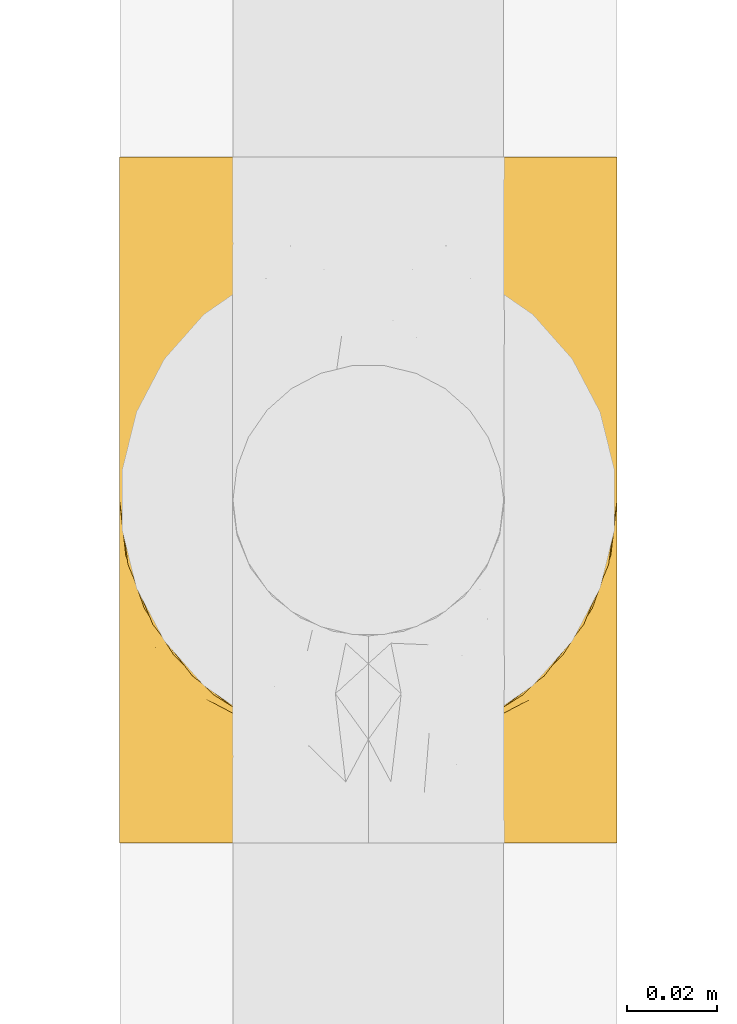
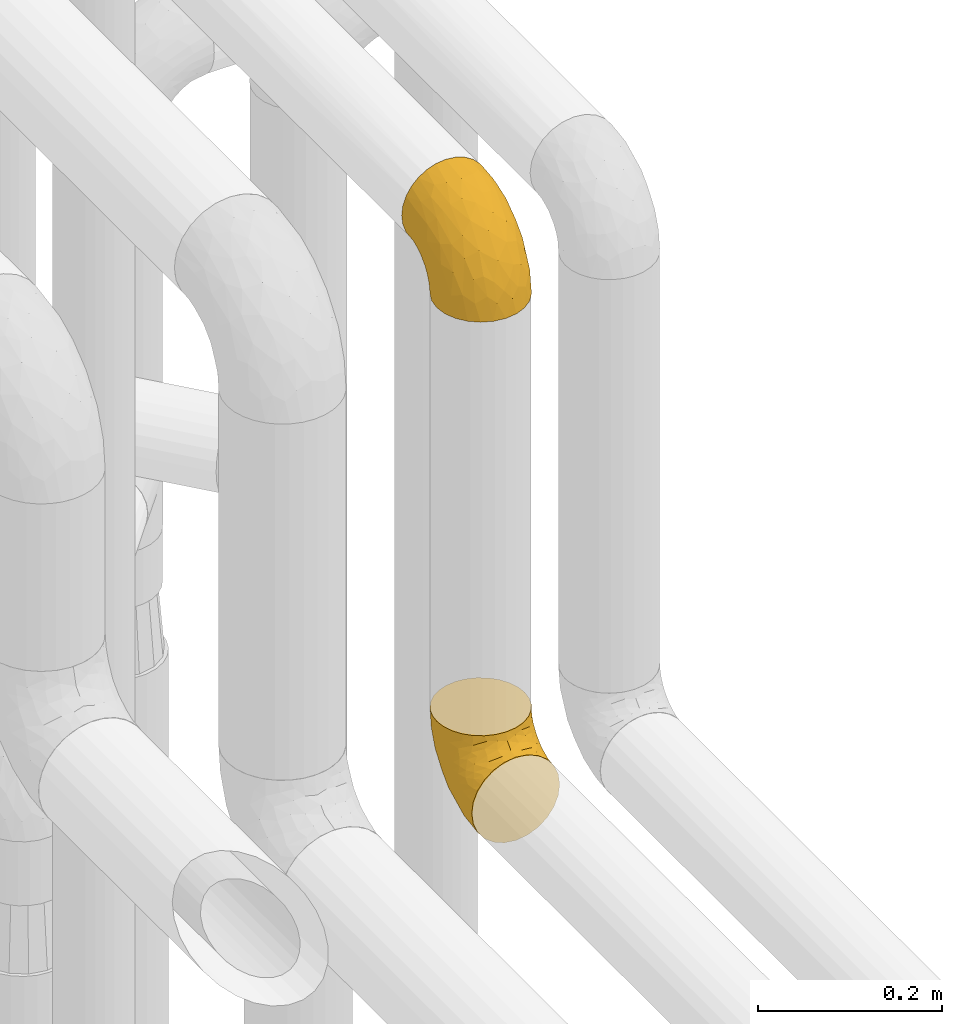
# One storey, part 188 of 827: 2 coverings.
"""IFC2X3 building model written with IfcOpenShell, lengths in millimetres."""

from ifc_helpers import new_model, entity, si_unit, converted_unit, derived_unit, direction, frame, origin, place, context, subcontext, project, spatial, faceted_brep, element, save


model = new_model("IFC2X3")

# Units and contexts
model_context = context("Model", 3, precision=0.01, world=origin(), true_north=direction((6.12303176911189e-17, 1.0)))
body_context = subcontext(model_context, "Body", "Model", "MODEL_VIEW")
ifc_project = project(units=[si_unit("LENGTHUNIT", "METRE", prefix="MILLI"), si_unit("AREAUNIT", "SQUARE_METRE"), si_unit("VOLUMEUNIT", "CUBIC_METRE"), converted_unit("PLANEANGLEUNIT", "DEGREE", entity("IfcRatioMeasure", 0.0174532925199433), si_unit("PLANEANGLEUNIT", "RADIAN"), dimensions=[0, 0, 0, 0, 0, 0, 0]), si_unit("MASSUNIT", "GRAM", prefix="KILO"), derived_unit("MASSDENSITYUNIT", [(si_unit("MASSUNIT", "GRAM", prefix="KILO"), 1), (si_unit("LENGTHUNIT", "METRE"), -3)]), derived_unit("MOMENTOFINERTIAUNIT", [(si_unit("LENGTHUNIT", "METRE"), 4)]), si_unit("TIMEUNIT", "SECOND"), si_unit("FREQUENCYUNIT", "HERTZ"), si_unit("THERMODYNAMICTEMPERATUREUNIT", "DEGREE_CELSIUS"), derived_unit("THERMALTRANSMITTANCEUNIT", [(si_unit("MASSUNIT", "GRAM", prefix="KILO"), 1), (si_unit("THERMODYNAMICTEMPERATUREUNIT", "KELVIN"), -1), (si_unit("TIMEUNIT", "SECOND"), -3)]), derived_unit("VOLUMETRICFLOWRATEUNIT", [(si_unit("LENGTHUNIT", "METRE"), 3), (si_unit("TIMEUNIT", "SECOND"), -1)]), derived_unit("MASSFLOWRATEUNIT", [(si_unit("MASSUNIT", "GRAM", prefix="KILO"), 1), (si_unit("TIMEUNIT", "SECOND"), -1)]), derived_unit("ROTATIONALFREQUENCYUNIT", [(si_unit("TIMEUNIT", "SECOND"), -1)]), si_unit("ELECTRICCURRENTUNIT", "AMPERE"), si_unit("ELECTRICVOLTAGEUNIT", "VOLT"), si_unit("POWERUNIT", "WATT"), si_unit("FORCEUNIT", "NEWTON", prefix="KILO"), si_unit("ILLUMINANCEUNIT", "LUX"), si_unit("LUMINOUSFLUXUNIT", "LUMEN"), si_unit("LUMINOUSINTENSITYUNIT", "CANDELA"), derived_unit("USERDEFINED", [(si_unit("MASSUNIT", "GRAM", prefix="KILO"), -1), (si_unit("LENGTHUNIT", "METRE"), -2), (si_unit("TIMEUNIT", "SECOND"), 3), (si_unit("LUMINOUSFLUXUNIT", "LUMEN"), 1)]), derived_unit("LINEARVELOCITYUNIT", [(si_unit("LENGTHUNIT", "METRE"), 1), (si_unit("TIMEUNIT", "SECOND"), -1)]), si_unit("PRESSUREUNIT", "PASCAL"), derived_unit("USERDEFINED", [(si_unit("LENGTHUNIT", "METRE"), -2), (si_unit("MASSUNIT", "GRAM", prefix="KILO"), 1), (si_unit("TIMEUNIT", "SECOND"), -2)]), derived_unit("LINEARFORCEUNIT", [(si_unit("MASSUNIT", "GRAM", prefix="KILO"), 1), (si_unit("LENGTHUNIT", "METRE"), 1), (si_unit("TIMEUNIT", "SECOND"), -2), (si_unit("LENGTHUNIT", "METRE"), -1)]), derived_unit("PLANARFORCEUNIT", [(si_unit("MASSUNIT", "GRAM", prefix="KILO"), 1), (si_unit("LENGTHUNIT", "METRE"), 1), (si_unit("TIMEUNIT", "SECOND"), -2), (si_unit("LENGTHUNIT", "METRE"), -2)])], contexts=[model_context])

# Site, building, storey
site_placement = place(None, origin())
site = spatial("IfcSite", under=ifc_project, at=site_placement, CompositionType="ELEMENT")
building_placement = place(site_placement, origin())
building = spatial("IfcBuilding", under=site, at=building_placement, CompositionType="ELEMENT")
storey_placement = place(building_placement, frame((0.0, 0.0, 28200.0)))
storey = spatial("IfcBuildingStorey", under=building, at=storey_placement, Name="08", CompositionType="ELEMENT", Elevation=28200.0)

# Coverings
covering_1_placement = place(storey_placement, frame((36411.97, 8729.79, 2793.25)))
element("IfcCovering", 1, at=covering_1_placement, inside=storey, Name=":ADSK_", ObjectType=":ADSK_", PredefinedType="INSULATION", context=body_context, shape_type="Brep", body=[
    faceted_brep([(111.9, 77.6, 132.75), (110.51, 89.87, 132.75), (106.43, 101.53, 132.75), (99.86, 111.99, 132.75), (91.12, 120.72, 132.75), (80.66, 127.29, 132.75), (69.0, 131.37, 132.75), (56.75, 132.75, 132.75), (44.47, 131.36, 132.75), (32.81, 127.28, 132.75), (22.35, 120.71, 132.75), (13.62, 111.97, 132.75), (7.05, 101.51, 132.75), (2.97, 89.85, 132.75), (1.6, 77.6, 132.75), (2.55, 69.16, 132.75), (2.98, 65.32, 132.75), (5.02, 59.49, 132.75), (7.06, 53.66, 132.75), (13.63, 43.2, 132.75), (22.37, 34.47, 132.75), (32.83, 27.9, 132.75), (44.49, 23.82, 132.75), (56.75, 22.45, 132.75), (69.02, 23.83, 132.75), (80.68, 27.91, 132.75), (91.14, 34.48, 132.75), (99.87, 43.22, 132.75), (106.44, 53.68, 132.75), (108.48, 59.51, 132.75), (110.52, 65.34, 132.75), (110.95, 69.16, 132.75), (42.47, 1.6, 110.02), (29.17, 1.6, 104.51), (17.75, 1.6, 95.74), (13.37, 1.6, 90.03), (8.98, 1.6, 84.32), (3.47, 1.6, 71.02), (2.71, 1.6, 65.22), (2.15, 1.6, 60.98), (1.6, 1.6, 56.75), (3.47, 1.6, 42.47), (8.98, 1.6, 29.17), (17.75, 1.6, 17.75), (29.17, 1.6, 8.98), (42.47, 1.6, 3.47), (56.75, 1.6, 1.6), (71.02, 1.6, 3.47), (84.32, 1.6, 8.98), (95.74, 1.6, 17.75), (104.51, 1.6, 29.17), (110.02, 1.6, 42.47), (111.9, 1.6, 56.75), (110.78, 1.6, 65.22), (110.02, 1.6, 71.02), (104.51, 1.6, 84.32), (100.12, 1.6, 90.03), (95.74, 1.6, 95.74), (84.32, 1.6, 104.51), (71.02, 1.6, 110.02), (56.75, 1.6, 111.9), (106.06, 28.25, 35.64), (110.5, 28.05, 48.47), (56.75, 35.54, 6.06), (66.53, 23.72, 4.36), (76.28, 54.78, 16.79), (86.35, 51.46, 20.82), (75.96, 32.52, 8.85), (88.56, 24.83, 13.94), (110.32, 74.1, 80.96), (111.9, 71.81, 103.66), (111.9, 67.69, 97.5), (111.9, 63.57, 91.33), (111.9, 59.45, 85.17), (111.9, 55.34, 79.01), (107.8, 58.92, 54.67), (101.47, 55.74, 38.99), (73.78, 79.4, 30.54), (56.75, 67.17, 19.17), (56.75, 94.33, 40.01), (98.04, 32.99, 24.66), (101.71, 106.92, 109.14), (56.75, 128.28, 98.8), (73.2, 126.45, 101.8), (104.0, 79.53, 63.23), (110.96, 84.54, 109.61), (111.08, 50.75, 62.85), (111.9, 49.17, 74.89), (111.9, 43.01, 70.77), (111.9, 36.84, 66.65), (111.9, 30.68, 62.53), (93.24, 114.68, 101.4), (98.07, 101.43, 80.83), (66.48, 47.48, 10.81), (82.04, 114.6, 79.3), (71.11, 104.36, 54.37), (68.82, 118.74, 76.81), (84.42, 123.15, 109.78), (84.13, 92.32, 48.41), (111.9, 75.8, 123.73), (111.9, 74.01, 114.72), (90.72, 109.06, 80.6), (89.42, 72.33, 35.27), (105.96, 91.49, 86.96), (107.26, 97.2, 110.67), (56.75, 115.17, 67.17), (96.16, 82.9, 52.02), (111.9, 19.62, 60.33), (111.9, 15.12, 59.44), (111.9, 10.61, 58.54), (106.76, 18.58, 82.8), (110.57, 23.94, 72.79), (110.3, 31.67, 77.6), (110.29, 14.6, 71.3), (94.17, 8.82, 98.0), (101.01, 11.25, 90.73), (98.9, 19.1, 96.3), (105.68, 10.16, 82.91), (106.0, 25.58, 87.53), (103.59, 28.81, 94.55), (67.59, 22.14, 125.07), (82.4, 24.42, 117.99), (78.41, 25.95, 125.94), (103.94, 45.04, 113.64), (109.96, 55.97, 103.99), (108.51, 56.25, 116.68), (95.93, 23.76, 102.88), (91.02, 25.8, 110.61), (82.23, 19.45, 112.36), (69.32, 9.94, 112.06), (87.66, 9.51, 103.46), (99.66, 42.14, 124.54), (92.5, 33.36, 120.6), (110.75, 64.73, 118.13), (108.97, 46.95, 96.16), (94.99, 32.04, 113.04), (111.03, 64.07, 110.58), (70.18, 17.51, 116.83), (56.75, 19.65, 122.32), (56.75, 12.02, 114.69), (104.65, 40.13, 103.01), (84.42, 14.17, 107.4), (106.33, 37.89, 95.69), (108.73, 36.57, 87.01), (110.14, 45.0, 88.18), (99.67, 32.43, 105.15), (29.08, 14.17, 107.4), (25.83, 9.51, 103.46), (3.2, 31.67, 77.6), (1.6, 36.84, 66.65), (2.92, 23.94, 72.79), (44.17, 9.94, 112.06), (1.6, 75.8, 123.73), (1.6, 74.01, 114.72), (3.35, 45.01, 88.19), (1.6, 55.34, 79.01), (1.6, 49.17, 74.89), (43.33, 17.51, 116.83), (45.92, 22.13, 125.08), (21.01, 33.34, 120.61), (31.11, 24.4, 117.98), (35.1, 25.94, 125.94), (1.6, 19.62, 60.33), (1.6, 10.61, 58.54), (1.6, 6.1, 57.64), (17.57, 23.74, 102.88), (22.49, 25.77, 110.61), (13.83, 32.4, 105.15), (19.33, 8.81, 98.0), (11.9, 15.06, 90.96), (4.99, 56.22, 116.68), (1.6, 30.68, 62.53), (3.2, 14.6, 71.3), (6.74, 18.58, 82.8), (7.5, 25.57, 87.53), (7.81, 10.16, 82.91), (4.53, 46.95, 96.19), (1.6, 59.45, 85.17), (1.6, 71.81, 103.66), (2.75, 64.71, 118.15), (13.84, 42.12, 124.54), (18.52, 32.02, 113.04), (9.57, 45.02, 113.63), (3.54, 55.95, 103.99), (9.91, 28.8, 94.56), (2.46, 64.06, 110.59), (1.6, 67.69, 97.5), (14.6, 19.09, 96.3), (8.86, 40.12, 103.04), (7.16, 37.88, 95.7), (4.77, 36.56, 87.02), (31.28, 19.43, 112.37), (1.6, 63.57, 91.33), (1.6, 43.01, 70.77), (2.41, 50.75, 62.85), (7.44, 28.25, 35.64), (7.52, 91.48, 86.97), (3.17, 74.09, 80.97), (2.53, 84.53, 109.62), (47.01, 45.93, 10.24), (2.99, 28.05, 48.47), (37.53, 32.53, 8.85), (47.09, 23.48, 4.3), (24.94, 24.84, 13.95), (15.45, 33.0, 24.66), (27.14, 51.47, 20.83), (29.35, 92.32, 48.41), (42.38, 104.36, 54.37), (39.72, 79.4, 30.54), (5.69, 58.91, 54.67), (17.32, 82.89, 52.03), (12.02, 55.75, 39.0), (9.48, 79.52, 63.25), (11.77, 106.9, 109.14), (15.41, 101.41, 80.83), (31.43, 114.58, 79.27), (20.24, 114.67, 101.39), (22.76, 109.03, 80.58), (24.06, 72.32, 35.28), (40.27, 126.45, 101.78), (29.05, 123.14, 109.77), (43.27, 118.38, 76.83), (38.2, 57.08, 17.47), (6.22, 97.19, 110.68)], [[[0, 1, 2, 3, 4, 5, 6, 7, 8, 9, 10, 11, 12, 13, 14, 15, 16, 17, 18, 19, 20, 21, 22, 23, 24, 25, 26, 27, 28, 29, 30, 31]], [[32, 33, 34, 35, 36, 37, 38, 39, 40, 41, 42, 43, 44, 45, 46, 47, 48, 49, 50, 51, 52, 53, 54, 55, 56, 57, 58, 59, 60]], [[51, 61, 62]], [[46, 63, 64]], [[65, 66, 67]], [[67, 66, 68]], [[69, 70, 71, 72, 73, 74]], [[75, 61, 76]], [[77, 78, 79]], [[61, 50, 80]], [[49, 80, 50]], [[68, 49, 48]], [[81, 3, 2]], [[82, 6, 83]], [[48, 47, 67]], [[52, 51, 62]], [[84, 75, 76]], [[85, 1, 0]], [[86, 74, 87, 88, 89, 90]], [[91, 81, 92]], [[93, 65, 67]], [[94, 95, 96]], [[49, 68, 80]], [[79, 95, 77]], [[5, 83, 6]], [[82, 83, 96]], [[97, 5, 4]], [[6, 82, 7]], [[84, 69, 75]], [[86, 69, 74]], [[98, 77, 95]], [[97, 83, 5]], [[85, 0, 99, 100, 70]], [[101, 91, 92]], [[77, 98, 102]], [[91, 4, 3]], [[103, 104, 85]], [[103, 81, 104]], [[102, 76, 80]], [[64, 93, 67]], [[97, 94, 83]], [[47, 64, 67]], [[50, 61, 51]], [[81, 91, 3]], [[96, 95, 105]], [[79, 105, 95]], [[101, 98, 94]], [[4, 91, 97]], [[94, 97, 91]], [[104, 81, 2]], [[92, 81, 103]], [[84, 92, 103]], [[106, 98, 101]], [[76, 61, 80]], [[75, 86, 62]], [[102, 80, 66]], [[84, 76, 106]], [[75, 62, 61]], [[62, 90, 107, 108, 109, 52]], [[70, 69, 85]], [[103, 85, 69]], [[94, 98, 95]], [[102, 98, 106]], [[2, 1, 104]], [[85, 104, 1]], [[67, 68, 48]], [[80, 68, 66]], [[62, 86, 90]], [[69, 86, 75]], [[76, 102, 106]], [[77, 102, 66]], [[92, 84, 106]], [[69, 84, 103]], [[46, 64, 47]], [[93, 64, 63]], [[63, 78, 93]], [[77, 93, 78]], [[93, 77, 65]], [[77, 66, 65]], [[82, 96, 105]], [[94, 96, 83]], [[101, 92, 106]], [[94, 91, 101]], [[110, 111, 112]], [[107, 90, 113]], [[114, 115, 116]], [[54, 107, 113]], [[115, 56, 117]], [[118, 119, 116]], [[120, 121, 122]], [[123, 124, 125]], [[99, 0, 31, 30, 100]], [[126, 127, 128]], [[129, 60, 59]], [[58, 114, 130]], [[131, 132, 123]], [[29, 28, 133]], [[130, 59, 58]], [[114, 58, 57]], [[134, 72, 124]], [[121, 127, 135]], [[26, 25, 132]], [[27, 131, 125]], [[27, 125, 28]], [[136, 133, 125]], [[120, 137, 121]], [[137, 138, 139]], [[126, 116, 119]], [[133, 70, 100]], [[138, 120, 23]], [[100, 29, 133]], [[123, 135, 140]], [[129, 141, 128]], [[53, 52, 109, 108, 107, 54]], [[25, 122, 132]], [[24, 122, 25]], [[55, 113, 117]], [[26, 131, 27]], [[142, 119, 143]], [[111, 89, 112]], [[112, 87, 143]], [[144, 134, 142]], [[118, 110, 112]], [[129, 137, 139]], [[128, 141, 126]], [[111, 113, 90]], [[54, 113, 55]], [[74, 73, 144]], [[145, 142, 140]], [[122, 24, 120]], [[132, 122, 121]], [[23, 120, 24]], [[137, 120, 138]], [[60, 129, 139]], [[141, 129, 59]], [[100, 30, 29]], [[28, 125, 133]], [[134, 124, 123]], [[124, 71, 136]], [[89, 88, 87, 112]], [[111, 110, 117]], [[143, 87, 144]], [[118, 116, 115]], [[112, 143, 118]], [[119, 118, 143]], [[143, 144, 142]], [[126, 119, 145]], [[127, 126, 145]], [[130, 126, 141]], [[140, 142, 134]], [[145, 119, 142]], [[135, 127, 145]], [[127, 121, 128]], [[121, 137, 128]], [[129, 128, 137]], [[73, 72, 134]], [[111, 90, 89]], [[74, 144, 87]], [[134, 123, 140]], [[135, 123, 132]], [[140, 135, 145]], [[121, 135, 132]], [[132, 131, 26]], [[125, 131, 123]], [[115, 114, 57]], [[116, 126, 130]], [[111, 117, 113]], [[115, 110, 118]], [[115, 117, 110]], [[115, 57, 56]], [[56, 55, 117]], [[116, 130, 114]], [[59, 130, 141]], [[144, 73, 134]], [[124, 136, 125]], [[70, 133, 136]], [[71, 124, 72]], [[71, 70, 136]], [[32, 146, 147]], [[148, 149, 150]], [[60, 139, 151]], [[15, 14, 152, 153, 16]], [[154, 155, 156]], [[138, 157, 139]], [[138, 158, 157]], [[159, 160, 161]], [[39, 38, 37, 162, 163, 164, 40]], [[165, 166, 167]], [[168, 169, 34]], [[33, 168, 34]], [[170, 19, 18]], [[171, 162, 172]], [[173, 174, 148]], [[169, 173, 175]], [[161, 158, 22]], [[154, 176, 177]], [[23, 22, 158]], [[178, 179, 153]], [[172, 37, 36]], [[20, 19, 180]], [[21, 20, 159]], [[167, 166, 181]], [[170, 182, 180]], [[182, 170, 183]], [[167, 184, 165]], [[185, 186, 183]], [[170, 179, 185]], [[17, 153, 179]], [[157, 151, 139]], [[187, 168, 147]], [[182, 188, 181]], [[22, 21, 161]], [[189, 154, 190]], [[180, 159, 20]], [[172, 150, 171]], [[190, 184, 189]], [[188, 167, 181]], [[190, 174, 184]], [[166, 191, 160]], [[151, 146, 32]], [[37, 172, 162]], [[175, 36, 35]], [[188, 176, 189]], [[176, 182, 183]], [[159, 161, 21]], [[158, 160, 157]], [[158, 161, 160]], [[23, 158, 138]], [[151, 157, 191]], [[60, 151, 32]], [[170, 18, 179]], [[17, 16, 153]], [[183, 170, 185]], [[179, 178, 185]], [[175, 150, 172]], [[150, 173, 148]], [[173, 169, 174]], [[154, 156, 190]], [[184, 174, 187]], [[190, 148, 174]], [[165, 184, 187]], [[189, 176, 154]], [[147, 165, 187]], [[191, 166, 165]], [[184, 167, 189]], [[188, 189, 167]], [[191, 165, 146]], [[181, 160, 159]], [[151, 191, 146]], [[157, 160, 191]], [[176, 192, 177]], [[148, 190, 156]], [[149, 148, 156, 193]], [[149, 171, 150]], [[182, 176, 188]], [[160, 181, 166]], [[181, 159, 182]], [[170, 180, 19]], [[159, 180, 182]], [[147, 168, 33]], [[169, 168, 187]], [[174, 169, 187]], [[35, 169, 175]], [[150, 175, 173]], [[34, 169, 35]], [[172, 36, 175]], [[32, 147, 33]], [[147, 146, 165]], [[192, 176, 183]], [[155, 154, 177]], [[192, 183, 186]], [[185, 178, 186]], [[179, 18, 17]], [[194, 171, 149, 193, 156, 155]], [[195, 42, 41]], [[196, 197, 198]], [[78, 63, 199]], [[197, 155, 177, 192, 186, 178]], [[200, 40, 164, 163, 162, 171]], [[201, 199, 202]], [[203, 204, 205]], [[46, 45, 202]], [[206, 207, 208]], [[194, 197, 209]], [[203, 201, 44]], [[44, 201, 45]], [[43, 203, 44]], [[210, 211, 212]], [[204, 43, 42]], [[212, 197, 196]], [[78, 208, 79]], [[198, 178, 153, 152, 14]], [[204, 195, 211]], [[14, 13, 198]], [[196, 213, 214]], [[206, 215, 207]], [[213, 11, 216]], [[204, 42, 195]], [[11, 213, 12]], [[210, 217, 206]], [[216, 11, 10]], [[210, 206, 218]], [[219, 220, 9]], [[220, 10, 9]], [[207, 105, 79]], [[221, 207, 215]], [[222, 199, 201]], [[8, 7, 82]], [[8, 82, 219]], [[209, 195, 200]], [[215, 216, 220]], [[9, 8, 219]], [[207, 79, 208]], [[221, 82, 105]], [[12, 213, 223]], [[222, 201, 205]], [[204, 211, 218]], [[221, 215, 219]], [[215, 220, 219]], [[216, 10, 220]], [[214, 213, 216]], [[223, 213, 196]], [[217, 214, 216]], [[212, 214, 210]], [[200, 195, 41]], [[211, 195, 209]], [[212, 211, 209]], [[211, 210, 218]], [[40, 200, 41]], [[200, 171, 194]], [[198, 13, 223]], [[197, 178, 198]], [[218, 208, 205]], [[210, 214, 217]], [[198, 223, 196]], [[13, 12, 223]], [[204, 203, 43]], [[201, 203, 205]], [[197, 194, 155]], [[200, 194, 209]], [[208, 218, 206]], [[218, 205, 204]], [[197, 212, 209]], [[214, 212, 196]], [[205, 208, 222]], [[78, 222, 208]], [[78, 199, 222]], [[202, 199, 63]], [[46, 202, 63]], [[201, 202, 45]], [[82, 221, 219]], [[105, 207, 221]], [[216, 215, 217]], [[206, 217, 215]]]),
])
covering_2_placement = place(storey_placement, frame((36411.97, 8750.64, 3472.4)))
element("IfcCovering", 2, at=covering_2_placement, inside=storey, Name=":ADSK_", ObjectType=":ADSK_", PredefinedType="INSULATION", context=body_context, shape_type="Brep", body=[
    faceted_brep([(1.6, 132.75, 77.6), (2.98, 132.75, 89.87), (7.06, 132.75, 101.53), (13.63, 132.75, 111.99), (22.37, 132.75, 120.72), (32.83, 132.75, 127.29), (44.49, 132.75, 131.37), (56.75, 132.75, 132.75), (69.02, 132.75, 131.36), (80.68, 132.75, 127.28), (91.14, 132.75, 120.71), (99.87, 132.75, 111.97), (106.44, 132.75, 101.51), (110.52, 132.75, 89.85), (111.9, 132.75, 77.6), (110.94, 132.75, 69.16), (110.51, 132.75, 65.32), (108.47, 132.75, 59.49), (106.43, 132.75, 53.66), (99.86, 132.75, 43.2), (91.12, 132.75, 34.47), (80.66, 132.75, 27.9), (69.0, 132.75, 23.82), (56.75, 132.75, 22.45), (44.47, 132.75, 23.83), (32.81, 132.75, 27.91), (22.35, 132.75, 34.48), (13.62, 132.75, 43.22), (7.05, 132.75, 53.68), (5.01, 132.75, 59.51), (2.97, 132.75, 65.34), (2.55, 132.75, 69.16), (71.02, 110.02, 1.6), (84.32, 104.51, 1.6), (95.74, 95.74, 1.6), (100.12, 90.03, 1.6), (104.51, 84.32, 1.6), (110.02, 71.02, 1.6), (110.78, 65.22, 1.6), (111.34, 60.98, 1.6), (111.9, 56.75, 1.6), (110.02, 42.47, 1.6), (104.51, 29.17, 1.6), (95.74, 17.75, 1.6), (84.32, 8.98, 1.6), (71.02, 3.47, 1.6), (56.75, 1.6, 1.6), (42.47, 3.47, 1.6), (29.17, 8.98, 1.6), (17.75, 17.75, 1.6), (8.98, 29.17, 1.6), (3.47, 42.47, 1.6), (1.6, 56.75, 1.6), (2.71, 65.22, 1.6), (3.47, 71.02, 1.6), (8.98, 84.32, 1.6), (13.37, 90.03, 1.6), (17.75, 95.74, 1.6), (29.17, 104.51, 1.6), (42.47, 110.02, 1.6), (56.75, 111.9, 1.6), (7.44, 35.64, 28.25), (2.99, 48.47, 28.05), (56.75, 6.06, 35.54), (46.96, 4.36, 23.72), (37.21, 16.79, 54.78), (27.14, 20.82, 51.46), (37.53, 8.85, 32.52), (24.94, 13.94, 24.83), (3.17, 80.96, 74.1), (1.6, 103.66, 71.81), (1.6, 97.5, 67.69), (1.6, 91.33, 63.57), (1.6, 85.17, 59.45), (1.6, 79.01, 55.34), (5.69, 54.67, 58.92), (12.02, 38.99, 55.74), (39.71, 30.54, 79.4), (56.75, 19.17, 67.17), (56.75, 40.01, 94.33), (15.45, 24.66, 32.99), (11.78, 109.14, 106.92), (56.75, 98.8, 128.28), (40.29, 101.8, 126.45), (9.49, 63.23, 79.53), (2.53, 109.61, 84.54), (2.41, 62.85, 50.75), (1.6, 74.89, 49.17), (1.6, 70.77, 43.01), (1.6, 66.65, 36.84), (1.6, 62.53, 30.68), (20.26, 101.4, 114.68), (15.42, 80.83, 101.43), (47.01, 10.81, 47.48), (31.45, 79.3, 114.6), (42.38, 54.37, 104.36), (44.67, 76.81, 118.74), (29.07, 109.78, 123.15), (29.36, 48.41, 92.32), (1.6, 123.73, 75.8), (1.6, 114.72, 74.01), (22.77, 80.6, 109.06), (24.08, 35.27, 72.33), (7.53, 86.96, 91.49), (6.23, 110.67, 97.2), (56.75, 67.17, 115.17), (17.33, 52.02, 82.9), (1.6, 60.33, 19.62), (1.6, 59.44, 15.12), (1.6, 58.54, 10.61), (6.73, 82.8, 18.58), (2.92, 72.79, 23.94), (3.19, 77.6, 31.67), (3.2, 71.3, 14.6), (19.32, 98.0, 8.82), (12.48, 90.73, 11.25), (14.6, 96.3, 19.1), (7.81, 82.91, 10.16), (7.5, 87.53, 25.58), (9.9, 94.55, 28.81), (45.9, 125.07, 22.14), (31.09, 117.99, 24.42), (35.08, 125.94, 25.95), (9.55, 113.64, 45.04), (3.53, 103.99, 55.97), (4.99, 116.68, 56.25), (17.56, 102.88, 23.76), (22.47, 110.61, 25.8), (31.26, 112.36, 19.45), (44.17, 112.06, 9.94), (25.83, 103.46, 9.51), (13.83, 124.54, 42.14), (20.99, 120.6, 33.36), (2.74, 118.13, 64.73), (4.52, 96.16, 46.95), (18.5, 113.04, 32.04), (2.46, 110.58, 64.07), (43.31, 116.83, 17.51), (56.75, 122.32, 19.65), (56.75, 114.69, 12.02), (8.84, 103.01, 40.13), (29.08, 107.4, 14.17), (7.16, 95.69, 37.89), (4.76, 87.01, 36.57), (3.35, 88.18, 45.0), (13.82, 105.15, 32.43), (84.41, 107.4, 14.17), (87.67, 103.46, 9.51), (110.29, 77.6, 31.67), (111.9, 66.65, 36.84), (110.57, 72.79, 23.94), (69.32, 112.06, 9.94), (111.9, 123.73, 75.8), (111.9, 114.72, 74.01), (110.14, 88.19, 45.01), (111.9, 79.01, 55.34), (111.9, 74.89, 49.17), (70.16, 116.83, 17.51), (67.57, 125.08, 22.13), (92.48, 120.61, 33.34), (82.38, 117.98, 24.4), (78.39, 125.94, 25.94), (111.9, 60.33, 19.62), (111.9, 58.54, 10.61), (111.9, 57.64, 6.1), (95.92, 102.88, 23.74), (91.0, 110.61, 25.77), (99.66, 105.15, 32.4), (94.16, 98.0, 8.81), (101.59, 90.96, 15.06), (108.5, 116.68, 56.22), (111.9, 62.53, 30.68), (110.29, 71.3, 14.6), (106.76, 82.8, 18.58), (105.99, 87.53, 25.57), (105.68, 82.91, 10.16), (108.96, 96.19, 46.95), (111.9, 85.17, 59.45), (111.9, 103.66, 71.81), (110.74, 118.15, 64.71), (99.65, 124.54, 42.12), (94.97, 113.04, 32.02), (103.92, 113.63, 45.02), (109.95, 103.99, 55.95), (103.58, 94.56, 28.8), (111.03, 110.59, 64.06), (111.9, 97.5, 67.69), (98.89, 96.3, 19.09), (104.63, 103.04, 40.12), (106.33, 95.7, 37.88), (108.72, 87.02, 36.56), (82.21, 112.37, 19.43), (111.9, 91.33, 63.57), (111.9, 70.77, 43.01), (111.08, 62.85, 50.75), (106.06, 35.64, 28.25), (105.97, 86.97, 91.48), (110.32, 80.97, 74.09), (110.96, 109.62, 84.53), (66.48, 10.24, 45.93), (110.5, 48.47, 28.05), (75.96, 8.85, 32.53), (66.4, 4.3, 23.48), (88.55, 13.95, 24.84), (98.04, 24.66, 33.0), (86.35, 20.83, 51.47), (84.14, 48.41, 92.32), (71.11, 54.37, 104.36), (73.77, 30.54, 79.4), (107.8, 54.67, 58.91), (96.17, 52.03, 82.89), (101.47, 39.0, 55.75), (104.01, 63.25, 79.52), (101.72, 109.14, 106.9), (98.08, 80.83, 101.41), (82.06, 79.27, 114.58), (93.25, 101.39, 114.67), (90.73, 80.58, 109.03), (89.43, 35.28, 72.32), (73.22, 101.78, 126.45), (84.44, 109.77, 123.14), (70.22, 76.83, 118.38), (75.29, 17.47, 57.08), (107.27, 110.68, 97.19)], [[[0, 1, 2, 3, 4, 5, 6, 7, 8, 9, 10, 11, 12, 13, 14, 15, 16, 17, 18, 19, 20, 21, 22, 23, 24, 25, 26, 27, 28, 29, 30, 31]], [[32, 33, 34, 35, 36, 37, 38, 39, 40, 41, 42, 43, 44, 45, 46, 47, 48, 49, 50, 51, 52, 53, 54, 55, 56, 57, 58, 59, 60]], [[51, 61, 62]], [[46, 63, 64]], [[65, 66, 67]], [[67, 66, 68]], [[69, 70, 71, 72, 73, 74]], [[75, 61, 76]], [[77, 78, 79]], [[61, 50, 80]], [[49, 80, 50]], [[68, 49, 48]], [[81, 3, 2]], [[82, 6, 83]], [[48, 47, 67]], [[52, 51, 62]], [[84, 75, 76]], [[85, 1, 0]], [[86, 74, 87, 88, 89, 90]], [[91, 81, 92]], [[93, 65, 67]], [[94, 95, 96]], [[49, 68, 80]], [[79, 95, 77]], [[5, 83, 6]], [[82, 83, 96]], [[97, 5, 4]], [[6, 82, 7]], [[84, 69, 75]], [[86, 69, 74]], [[98, 77, 95]], [[97, 83, 5]], [[85, 0, 99, 100, 70]], [[101, 91, 92]], [[77, 98, 102]], [[91, 4, 3]], [[103, 104, 85]], [[103, 81, 104]], [[102, 76, 80]], [[64, 93, 67]], [[97, 94, 83]], [[47, 64, 67]], [[50, 61, 51]], [[81, 91, 3]], [[96, 95, 105]], [[79, 105, 95]], [[101, 98, 94]], [[4, 91, 97]], [[94, 97, 91]], [[104, 81, 2]], [[92, 81, 103]], [[84, 92, 103]], [[106, 98, 101]], [[76, 61, 80]], [[75, 86, 62]], [[102, 80, 66]], [[84, 76, 106]], [[75, 62, 61]], [[62, 90, 107, 108, 109, 52]], [[70, 69, 85]], [[103, 85, 69]], [[94, 98, 95]], [[102, 98, 106]], [[2, 1, 104]], [[85, 104, 1]], [[67, 68, 48]], [[80, 68, 66]], [[62, 86, 90]], [[69, 86, 75]], [[76, 102, 106]], [[77, 102, 66]], [[92, 84, 106]], [[69, 84, 103]], [[46, 64, 47]], [[93, 64, 63]], [[63, 78, 93]], [[77, 93, 78]], [[93, 77, 65]], [[77, 66, 65]], [[82, 96, 105]], [[94, 96, 83]], [[101, 92, 106]], [[94, 91, 101]], [[110, 111, 112]], [[107, 90, 113]], [[114, 115, 116]], [[54, 107, 113]], [[115, 56, 117]], [[118, 119, 116]], [[120, 121, 122]], [[123, 124, 125]], [[99, 0, 31, 30, 100]], [[126, 127, 128]], [[129, 60, 59]], [[58, 114, 130]], [[131, 132, 123]], [[29, 28, 133]], [[130, 59, 58]], [[114, 58, 57]], [[134, 72, 124]], [[121, 127, 135]], [[26, 25, 132]], [[27, 131, 125]], [[27, 125, 28]], [[136, 133, 125]], [[120, 137, 121]], [[137, 138, 139]], [[126, 116, 119]], [[133, 70, 100]], [[138, 120, 23]], [[100, 29, 133]], [[123, 135, 140]], [[129, 141, 128]], [[53, 52, 109, 108, 107, 54]], [[25, 122, 132]], [[24, 122, 25]], [[55, 113, 117]], [[26, 131, 27]], [[142, 119, 143]], [[111, 89, 112]], [[112, 87, 143]], [[144, 134, 142]], [[118, 110, 112]], [[129, 137, 139]], [[128, 141, 126]], [[111, 113, 90]], [[54, 113, 55]], [[74, 73, 144]], [[145, 142, 140]], [[122, 24, 120]], [[132, 122, 121]], [[23, 120, 24]], [[137, 120, 138]], [[60, 129, 139]], [[141, 129, 59]], [[100, 30, 29]], [[28, 125, 133]], [[134, 124, 123]], [[124, 71, 136]], [[89, 88, 87, 112]], [[111, 110, 117]], [[143, 87, 144]], [[118, 116, 115]], [[112, 143, 118]], [[119, 118, 143]], [[143, 144, 142]], [[126, 119, 145]], [[127, 126, 145]], [[130, 126, 141]], [[140, 142, 134]], [[145, 119, 142]], [[135, 127, 145]], [[127, 121, 128]], [[121, 137, 128]], [[129, 128, 137]], [[73, 72, 134]], [[111, 90, 89]], [[74, 144, 87]], [[134, 123, 140]], [[135, 123, 132]], [[140, 135, 145]], [[121, 135, 132]], [[132, 131, 26]], [[125, 131, 123]], [[115, 114, 57]], [[116, 126, 130]], [[115, 117, 110]], [[115, 110, 118]], [[56, 55, 117]], [[115, 57, 56]], [[111, 117, 113]], [[116, 130, 114]], [[59, 130, 141]], [[144, 73, 134]], [[124, 136, 125]], [[70, 133, 136]], [[71, 124, 72]], [[71, 70, 136]], [[32, 146, 147]], [[148, 149, 150]], [[60, 139, 151]], [[15, 14, 152, 153, 16]], [[154, 155, 156]], [[138, 157, 139]], [[138, 158, 157]], [[159, 160, 161]], [[39, 38, 37, 162, 163, 164, 40]], [[165, 166, 167]], [[168, 169, 34]], [[33, 168, 34]], [[170, 19, 18]], [[171, 162, 172]], [[173, 174, 148]], [[169, 173, 175]], [[161, 158, 22]], [[154, 176, 177]], [[23, 22, 158]], [[178, 179, 153]], [[172, 37, 36]], [[20, 19, 180]], [[21, 20, 159]], [[167, 166, 181]], [[170, 182, 180]], [[182, 170, 183]], [[167, 184, 165]], [[185, 186, 183]], [[170, 179, 185]], [[17, 153, 179]], [[157, 151, 139]], [[187, 168, 147]], [[182, 188, 181]], [[22, 21, 161]], [[189, 154, 190]], [[180, 159, 20]], [[172, 150, 171]], [[190, 184, 189]], [[188, 167, 181]], [[190, 174, 184]], [[166, 191, 160]], [[151, 146, 32]], [[37, 172, 162]], [[175, 36, 35]], [[188, 176, 189]], [[176, 182, 183]], [[159, 161, 21]], [[158, 160, 157]], [[158, 161, 160]], [[23, 158, 138]], [[151, 157, 191]], [[60, 151, 32]], [[170, 18, 179]], [[17, 16, 153]], [[183, 170, 185]], [[179, 178, 185]], [[175, 150, 172]], [[150, 173, 148]], [[173, 169, 174]], [[154, 156, 190]], [[184, 174, 187]], [[190, 148, 174]], [[165, 184, 187]], [[189, 176, 154]], [[147, 165, 187]], [[191, 166, 165]], [[184, 167, 189]], [[188, 189, 167]], [[191, 165, 146]], [[181, 160, 159]], [[151, 191, 146]], [[157, 160, 191]], [[176, 192, 177]], [[148, 190, 156]], [[149, 148, 156, 193]], [[149, 171, 150]], [[182, 176, 188]], [[160, 181, 166]], [[181, 159, 182]], [[170, 180, 19]], [[159, 180, 182]], [[147, 168, 33]], [[169, 168, 187]], [[174, 169, 187]], [[35, 169, 175]], [[150, 175, 173]], [[34, 169, 35]], [[172, 36, 175]], [[32, 147, 33]], [[147, 146, 165]], [[192, 176, 183]], [[155, 154, 177]], [[192, 183, 186]], [[185, 178, 186]], [[179, 18, 17]], [[194, 171, 149, 193, 156, 155]], [[195, 42, 41]], [[196, 197, 198]], [[78, 63, 199]], [[197, 155, 177, 192, 186, 178]], [[200, 40, 164, 163, 162, 171]], [[201, 199, 202]], [[203, 204, 205]], [[46, 45, 202]], [[206, 207, 208]], [[194, 197, 209]], [[203, 201, 44]], [[44, 201, 45]], [[43, 203, 44]], [[210, 211, 212]], [[204, 43, 42]], [[212, 197, 196]], [[78, 208, 79]], [[198, 178, 153, 152, 14]], [[204, 195, 211]], [[14, 13, 198]], [[196, 213, 214]], [[206, 215, 207]], [[213, 11, 216]], [[204, 42, 195]], [[11, 213, 12]], [[210, 217, 206]], [[216, 11, 10]], [[210, 206, 218]], [[219, 220, 9]], [[220, 10, 9]], [[207, 105, 79]], [[221, 207, 215]], [[222, 199, 201]], [[8, 7, 82]], [[8, 82, 219]], [[209, 195, 200]], [[215, 216, 220]], [[9, 8, 219]], [[207, 79, 208]], [[221, 82, 105]], [[12, 213, 223]], [[222, 201, 205]], [[204, 211, 218]], [[221, 215, 219]], [[215, 220, 219]], [[216, 10, 220]], [[214, 213, 216]], [[223, 213, 196]], [[217, 214, 216]], [[212, 214, 210]], [[200, 195, 41]], [[211, 195, 209]], [[212, 211, 209]], [[211, 210, 218]], [[40, 200, 41]], [[200, 171, 194]], [[198, 13, 223]], [[197, 178, 198]], [[218, 208, 205]], [[210, 214, 217]], [[198, 223, 196]], [[13, 12, 223]], [[204, 203, 43]], [[201, 203, 205]], [[197, 194, 155]], [[200, 194, 209]], [[208, 218, 206]], [[218, 205, 204]], [[197, 212, 209]], [[214, 212, 196]], [[205, 208, 222]], [[78, 222, 208]], [[78, 199, 222]], [[202, 199, 63]], [[46, 202, 63]], [[201, 202, 45]], [[82, 221, 219]], [[105, 207, 221]], [[216, 215, 217]], [[206, 217, 215]]]),
])

save(model, "model.ifc")
